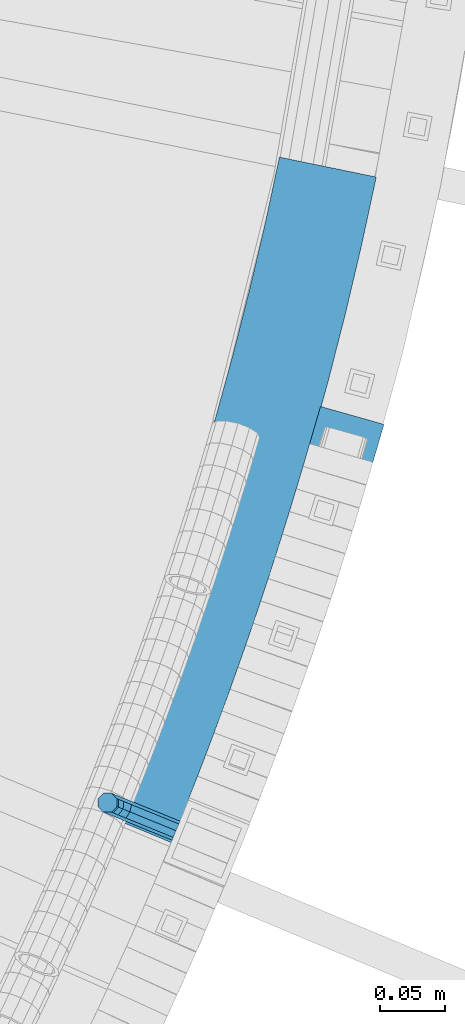
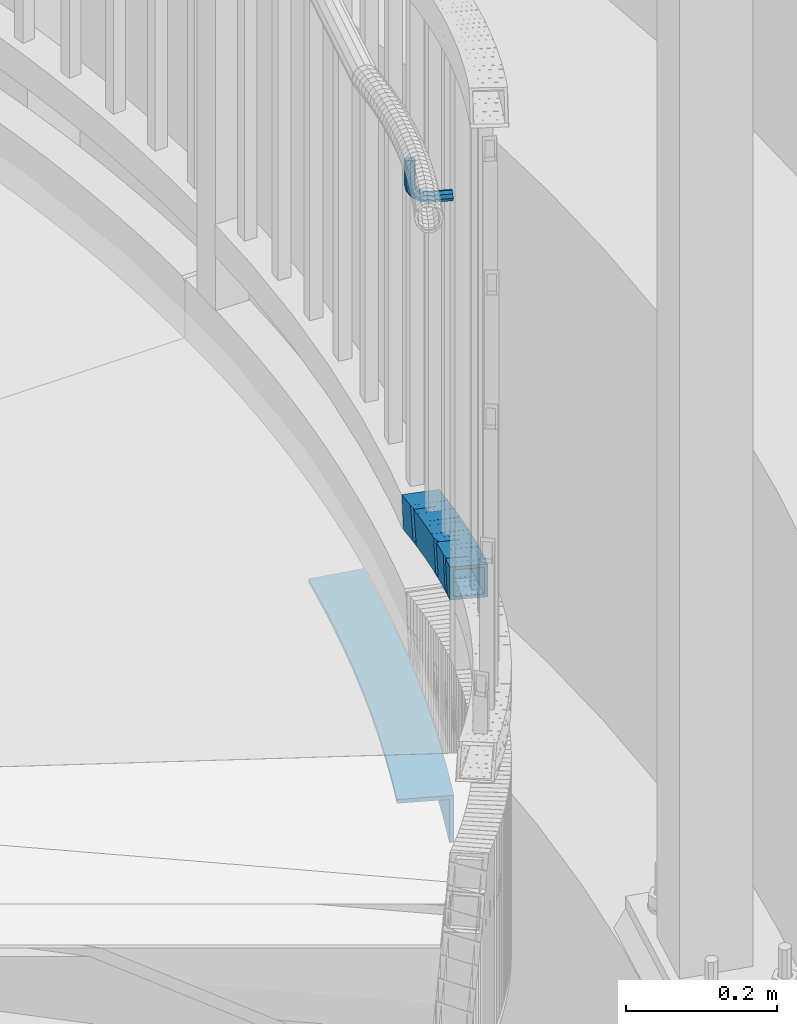
# One storey, part 495 of 975: 3 beams.
"""IFC2X3 building model written with IfcOpenShell, lengths in millimetres."""

from ifc_helpers import new_model, si_unit, frame, origin_with_axes, place, context, subcontext, project, spatial, faceted_brep, material, type_object, element, save


model = new_model("IFC2X3")

# Units and contexts
model_context = context("Model", 3, precision=1e-05, world=origin_with_axes())
body_context = subcontext(model_context, "Body", "Model", "MODEL_VIEW")
ifc_project = project(units=[si_unit("LENGTHUNIT", "METRE", prefix="MILLI"), si_unit("AREAUNIT", "SQUARE_METRE"), si_unit("VOLUMEUNIT", "CUBIC_METRE"), si_unit("MASSUNIT", "GRAM", prefix="KILO"), si_unit("TIMEUNIT", "SECOND"), si_unit("PLANEANGLEUNIT", "RADIAN"), si_unit("SOLIDANGLEUNIT", "STERADIAN"), si_unit("THERMODYNAMICTEMPERATUREUNIT", "DEGREE_CELSIUS"), si_unit("LUMINOUSINTENSITYUNIT", "LUMEN")], contexts=[model_context])

# Site, building, storey
site_placement = place(None, origin_with_axes())
site = spatial("IfcSite", under=ifc_project, at=site_placement, CompositionType="ELEMENT")
building_placement = place(site_placement, origin_with_axes())
building = spatial("IfcBuilding", under=site, at=building_placement, Name="Undefined", CompositionType="ELEMENT")
storey_placement = place(building_placement, origin_with_axes())
storey = spatial("IfcBuildingStorey", under=building, at=storey_placement, Name="Undefined", CompositionType="ELEMENT", Elevation=0.0)

# Beams
ifc_material_1 = material(Name="STEEL/A36")
beam_type_1 = type_object("IfcBeamType", PredefinedType="NOTDEFINED")
beam_1_placement = place(storey_placement, frame((37368.7829717512, 2329.61663625139, 3045.06408771674), z_axis=(0.0, 0.0, 1.0), x_axis=(-0.925815306032597, 0.377976215013284, 0.0)))
element("IfcBeam", 1, at=beam_1_placement, inside=storey, type_object=beam_type_1, material=ifc_material_1, Name="BRACKET", context=body_context, shape_type="Brep", body=[
    faceted_brep([(-4.22995071858168e-07, -7.93750000000728, 0.0), (-2.99107341561466e-07, -5.61266007567065, -5.61266007566792), (31.7499842270954, -5.6126618385606, -5.6126600757234), (31.7499840980236, -7.93750176289177, -5.54791768081486e-11), (-1.09139364212751e-11, 1.81898940354586e-12, -7.9375), (31.7499845387247, -1.7628881323617e-06, -7.93750000005548), (2.99089151667431e-07, 5.61266007567428, -5.61266007566792), (31.7499848503612, 5.61265831278433, -5.6126600757234), (4.22980519942939e-07, 7.93750000001091, 0.0), (31.7499849794513, 7.93749823711914, -5.54791768081486e-11), (2.99089151667431e-07, 5.61266007567428, 5.61266007566792), (31.7499848503794, 5.61265831278433, 5.61266007561244), (-1.09139364212751e-11, 1.81898940354586e-12, 7.9375), (31.7499845387538, -1.7628881323617e-06, 7.93749999994452), (-2.99107341561466e-07, -5.61266007567065, 5.61266007566792), (31.7499842271172, -5.6126618385606, 5.61266007561244), (44.5076933192395, -2.47124626184814e-06, -5.39983394420233), (43.618015285665, -5.61266249752225, -3.25196192174644), (41.4701431341346, -7.93750230259684, 1.9334598451087), (39.322271240766, -5.61266225900181, 7.11888161196475), (38.432593830461, -2.1339365048334e-06, 9.26675363442064), (39.3222718640282, 5.61265789233948, 7.11888161196475), (41.4701440155623, 7.93749769741771, 1.9334598451087), (43.6180159089272, 5.61265765382268, -3.25196192174644), (53.6792468227941, 5.61265709518557, 3.47073764605557), (55.32315658683, -3.07176742353477e-06, 1.82682757038583), (49.7104969518768, 7.93749723988003, 7.43948764606012), (45.7417468228014, 5.61265753590487, 11.4082376460638), (44.0978364355033, -2.44848706643097e-06, 13.0521477217335), (45.7417461995356, -5.61266261544006, 11.4082376460638), (49.7104960704528, -7.93750276013816, 7.43948764606012), (53.6792461995283, -5.612663056163, 3.47073764605648), (60.4019463906188, 5.61265672191075, 13.5319685599115), (62.5498181014409, -3.47302193404175e-06, 12.6422908379673), (55.2165247528465, 7.93749693416248, 15.6798405823693), (50.0311028569122, 5.61265729774459, 17.8277126048279), (47.8832305228243, -2.65866765403189e-06, 18.7173903267721), (50.03110223365, -5.61266285360034, 17.8277126048279), (55.2165238714188, -7.93750306585207, 15.6798405823693), (60.4019457673567, -5.61266342943782, 13.5319685599115), (62.7626445446149, 5.61265659083438, 25.3999996184748), (65.0874841573168, -3.61392449121922e-06, 25.3999996184748), (57.1499845980288, 7.93749682680573, 25.3999996184748), (51.5373243932772, 5.61265721410746, 25.3999996184748), (49.2124841573132, -2.73247496807016e-06, 25.3999996184748), (51.5373237700151, -5.61266293723384, 25.3999996184748), (57.1499837166011, -7.93750317320519, 25.3999996184748), (62.7626439213527, -5.61266356051055, 25.3999996184748), (65.0874827799671, -8.13710357761011e-07, 63.5532656203741), (62.7626427854739, -5.61266086031537, 61.7133802904182), (57.1499826807376, -7.93750071448449, 60.9512776088477), (51.5373226341253, -5.61266071998034, 61.7133869906074), (49.2124827799453, -6.15244061918929e-07, 63.5532750958728), (51.5373227744385, 5.61265943136095, 65.3931604258296), (57.1499828791711, 7.93749928552643, 66.1552631073992), (62.7626429257907, 5.61265929102228, 65.3931537256394)], [[[0, 1, 2, 3]], [[1, 4, 5, 2]], [[4, 6, 7, 5]], [[6, 8, 9, 7]], [[8, 10, 11, 9]], [[10, 12, 13, 11]], [[12, 14, 15, 13]], [[14, 0, 3, 15]], [[14, 12, 10, 8, 6, 4, 1, 0]], [[2, 5, 16, 17]], [[3, 2, 17, 18]], [[15, 3, 18, 19]], [[13, 15, 19, 20]], [[11, 13, 20, 21]], [[9, 11, 21, 22]], [[7, 9, 22, 23]], [[5, 7, 23, 16]], [[23, 24, 25, 16]], [[22, 26, 24, 23]], [[21, 27, 26, 22]], [[20, 28, 27, 21]], [[19, 29, 28, 20]], [[18, 30, 29, 19]], [[17, 31, 30, 18]], [[16, 25, 31, 17]], [[24, 32, 33, 25]], [[26, 34, 32, 24]], [[27, 35, 34, 26]], [[28, 36, 35, 27]], [[29, 37, 36, 28]], [[30, 38, 37, 29]], [[31, 39, 38, 30]], [[25, 33, 39, 31]], [[32, 40, 41, 33]], [[34, 42, 40, 32]], [[35, 43, 42, 34]], [[36, 44, 43, 35]], [[37, 45, 44, 36]], [[38, 46, 45, 37]], [[39, 47, 46, 38]], [[33, 41, 47, 39]], [[47, 41, 48, 49]], [[46, 47, 49, 50]], [[45, 46, 50, 51]], [[44, 45, 51, 52]], [[43, 44, 52, 53]], [[42, 43, 53, 54]], [[40, 42, 54, 55]], [[41, 40, 55, 48]], [[54, 53, 52, 51, 50, 49, 48, 55]]]),
])
ifc_material_2 = material()
beam_type_2 = type_object("IfcBeamType", Name="HSS2X2X.188_TUBES", PredefinedType="NOTDEFINED")
beam_2_placement = place(storey_placement, frame((37461.5164000018, 2508.53605289768, 2344.33794306487), z_axis=(-0.950871431631883, 0.309586047014935, 5.81717358727475e-11), x_axis=(0.294802179000737, 0.905463837001894, -0.305330829000651)))
element("IfcBeam", 2, at=beam_2_placement, inside=storey, type_object=beam_type_2, material=ifc_material_2, Name="HANDRAIL", ObjectType="HSS2X2X.188_TUBES", context=body_context, shape_type="Brep", body=[
    faceted_brep([(96.7366792999055, -25.8585898348501, -24.1435934114488), (96.8567889623937, 24.9389981357381, -24.6238329788175), (155.260260092999, 24.8173161677751, -22.8878853430069), (147.632993601499, -25.9646308554684, -22.6307837312488), (95.3485836847176, 25.4225931418969, 26.151470592049), (95.2284740222294, -25.3749948286913, 26.631710159425), (145.748198229005, -25.4802512345777, 28.1333263151173), (153.375464720504, 25.3016957886657, 27.8762247033665), (95.4787176486443, 20.6149822378266, 21.436308341712), (95.3811285478714, -20.6580579882757, 21.8265029902104), (96.6065453359843, -21.0509789307807, -19.4284311611191), (96.7041344367499, 20.2220612953224, -19.8186258096102), (154.36850429325, 20.1019192238045, -18.1046467500564), (152.837108053098, 20.4954776657778, 23.141192662617), (146.639954028753, -20.7648542906063, 23.3500877221668), (148.171350268904, -21.1584127325796, -17.8957516904993), (0.0, -25.400000000016, -25.4000000000196), (0.0, 25.3999999999724, -25.4000000000342), (18.9957890070255, 25.4000000000033, -25.3999999999287), (18.9957890070727, -25.4000000000106, -25.4000000000524), (0.0, 25.400000000016, 25.4000000000196), (0.0, -25.399999999976, 25.4000000000378), (18.9957890070546, -25.4000000000069, 25.3999999999796), (18.9957890070091, 25.4000000000078, 25.400000000096), (0.0, 20.6375000000116, 20.6375000000189), (0.0, -20.6374999999825, 20.6375000000335), (0.0, -20.6375000000153, -20.6375000000153), (0.0, 20.6374999999753, -20.6375000000298), (18.9957890070273, 20.6375000000025, -20.6374999999316), (18.9957890070145, 20.6375000000044, 20.6375000000917), (18.9957890070527, -20.6375000000062, 20.6374999999825), (18.9957890070673, -20.6375000000089, -20.6375000000335), (77.1467147449421, 25.0530573657934, -24.8958697393682), (76.2325595611073, 25.3461745613404, 25.3909398963879), (77.1245082366768, 24.9711102747369, -24.8957957655512), (57.0505389284226, -25.420255620671, 25.8422657576812), (57.9738550767488, -25.7163102127006, -24.9484798459671), (77.062296197606, -25.7460184417378, -24.6013012215917), (76.1389800492798, -25.4499638497091, 26.1894443820565), (57.1349574757587, 25.378820186861, 25.5476972399265), (76.2233985966177, 25.3491119578212, 25.8948758642728), (76.2248761730079, 25.3486381837229, 25.8135957883424), (76.2409359542999, -20.7260543437278, 20.9879711992326), (95.037833513974, 25.4232092055199, 26.2494496363652), (77.3170498575291, -25.8277033336444, -24.5954890550638), (77.1264093380832, 24.9705007004559, -24.9777495746675), (96.2159033238313, 25.0454697247387, -24.5354838026979), (96.4065438432772, -25.7527343093607, -24.1532232830796), (76.0987368961723, 25.3488308277956, 25.8106682735597), (58.0582736240831, 25.0827655948324, -25.2430483637218), (57.2136041258509, 20.5886517119015, 20.8136806381226), (57.145014056141, -20.6855973817183, 21.0530175588065), (57.8952084266566, -20.926141737742, -20.2144632441559), (57.9637984963647, 20.3481073558787, -20.4538001648398), (77.0318333414216, 20.3184308860764, -20.1069926877462), (76.0748887157533, 20.5592970171401, 21.1567277626164), (76.2313441815368, -20.7153023253159, 21.4001577886011), (76.9836495475156, -20.9558499667801, -19.8672846197951), (76.2335949006829, -20.7153504121379, 21.3925101158457), (77.0521163327339, 20.2442123710844, -20.1061913538651), (77.0321149689626, 20.2441345752723, -20.1065545017191), (76.0766561215969, 20.5504954767166, 21.0819332781903), (95.1661501073468, 20.6254645010004, 21.5241990501672), (95.3210455293975, -20.6480762767069, 21.8347857223562), (96.2782272499062, -20.9549896048411, -19.4279726968889), (77.18873326416, -21.0299586291248, -19.8702384688659), (76.233581902763, -20.7230373272814, 21.3925669897799), (77.1398518623064, 20.9233002661749, -24.87192252362), (77.0534646332853, 20.2436592277027, -20.1803704271661), (77.0473682223146, 16.6382677249621, -20.1536948636858), (96.1233318278537, 20.3185511728652, -19.7385593690706), (19.586033212543, -25.5892574927839, -25.3962183114199), (57.6407831223223, -25.609513103911, -24.9539525402652), (57.0797740346807, 25.3793846395083, 25.6533352330734), (19.0250241249014, 25.3996402506345, 25.2110694619114), (19.6152683263117, 25.2103827674473, -25.5851488363478), (19.0776187268693, 20.6194310871888, 20.4666362331627), (19.0538651969309, -20.6552766242494, 20.6201422846643), (19.5334386105769, -20.809048329339, -20.6517850826713), (19.5571921405153, 20.4656593821001, -20.8052911341729), (57.670018236091, 25.1901271563211, -25.1428830651857), (57.1086151067102, -20.6755322353765, 21.0624080558264), (57.1323686366468, 20.5991754760616, 20.9089020043248), (57.6119420502946, 20.4454037709729, -20.3630253630181), (57.5881885203562, -20.8293039404662, -20.2095193115165), (-0.0786638557456172, 20.6475389881271, 20.7362271898237), (-37.948109538167, 20.6083781665893, 20.9883187091109), (-38.2229557700066, 20.6965055955079, -20.2856721095741), (-0.353510087585164, 20.7356664170466, -20.5377636288613), (-0.338272282593607, -25.2915354817324, -25.3987579389068), (-0.390080096927704, 25.5083215646337, -25.2899460723711), (-0.0518078115874232, 25.399857036733, 25.5088118583226), (-0.0365700065995043, -20.627344862045, 20.6478175482698), (-0.311416238437232, -20.5392174331255, -20.6261732704224), (-37.9060156890191, -20.6665056835836, 20.8999090675497), (-38.1808619208587, -20.578378254665, -20.3740817511352), (-38.2077179650132, -25.330696303271, -25.1466664196269), (-37.8694456796748, -25.4391608311707, 25.6520915110668), (-37.9212534940125, 25.3606962151953, 25.7609033776025), (-38.259525779351, 25.4691607430959, -25.0378545530912), (-37.943759409578, 25.3598950076466, 25.9527627758289), (-56.8199193276287, 25.3302291871478, 26.2994459639885), (-56.7725825649541, -25.4688690501698, 25.9992701574374), (-57.7058817951656, -25.1696134773392, -24.79127422491), (-38.8027449019282, -25.1399052597571, -25.1384528773997), (-57.7801955330269, 25.6294423628979, -24.4906029540434), (-38.8770586397895, 25.6591505804781, -24.8377816065185), (-56.9462637977231, 25.3620482506194, 20.8923197386903), (-57.625351905257, -20.435257202269, -20.0014727574307), (-56.8670462807113, -20.6784023551954, 21.2658445532288), (-37.9639093874739, -20.6486941376133, 20.9186659007537), (-38.7222150120197, -20.4055489846887, -20.3486514099059), (-56.9274261927221, 20.5958305149961, 21.5101399608175), (-38.0242892994866, 20.6255387325764, 21.1629613083351), (-57.6857318172715, 20.8389756679226, -19.7571773498421), (-38.7825949240341, 20.8686838855037, -20.1043560023172), (-56.9260785297829, 20.6029855483157, 21.5841295916616), (-56.9300083051094, 20.6045886892689, 21.3702988910954), (-56.9232425980936, 18.6244839761293, 21.5692388421812), (-76.8919372546588, -25.1086059243789, -24.3431749339798), (-76.9373693852813, 25.6899398541536, -23.961490886446), (-58.0047522740515, 25.7101954522714, -24.4037566784391), (-57.9593201434291, -25.0883503262612, -24.7854407259729), (-94.5147354854525, 20.6310513116314, 22.5219002199374), (-95.5518787430665, 20.9636037124856, -18.7387271114276), (-76.8212670862304, 20.9178653238923, -19.2099157302509), (-75.8570207073572, 20.5854909303471, 22.0525454002418), (-94.6238209254952, -20.6424859953695, 22.1919857813118), (-75.8206549336992, -20.6884015548112, 21.7189719803937), (-76.8494265385525, -20.355869596744, -19.5418659488641), (-95.6609641831092, -20.3099335945153, -19.0686415500531), (-75.8123507604814, -20.6884003607756, 21.7160768465328), (-95.7932213405311, -25.0338933913781, -23.8675502158076), (-94.5167373311597, -25.4431886539678, 26.914760345855), (-94.3824783280324, 25.3550111084951, 27.3208088857064), (-95.658962337402, 25.7643063710848, -23.4615016759708), (-76.9816836959726, -25.0798293936059, -24.3407746146331), (-75.7051996866012, -25.4891246561983, 26.4415359470368), (-75.570940683474, 25.3090751062655, 26.8475844868808), (-75.6588445928173, 25.3095193284171, 26.8210758474961), (-76.8474246928436, 25.7183703688561, -23.9347260747891), (-75.5852489829049, 25.3136629578403, 26.278358002266), (-76.8475001488841, 25.6898208419307, -23.9349542815689), (-56.818014704686, 25.3296767253669, 26.3809542043455), (-75.9311365098765, -20.6556816945813, 16.9909494715321), (-76.9143961006303, 0.37908680601231, -24.1372722110609), (-76.8013446520472, -2.03941088464944, -19.4085056854019), (-76.7410614564778, 20.8919889944063, -19.2380944215984), (-76.7404094805424, 20.8917947019436, -19.2121583226326), (-75.812357800678, -20.6910784120755, 21.7160569449989), (-76.8212440386742, 20.8917071451742, -19.2101271392676), (-75.8576292007983, 20.5827310911591, 22.0263704716199), (-57.8892363646792, 20.9121581548861, -19.6784729126375), (-76.7849398697781, -20.3819158882879, -19.5463254092538), (-57.8523227585483, -20.3616602901711, -19.9885912012542), (-56.8880984834377, -20.6708317557805, 21.2739863910028), (-76.9366969028124, 25.6897242275663, -23.9327129757949), (-134.326123177927, -24.7553069966798, -22.47828815088), (-134.175492297347, 26.0399618437677, -21.80155055879), (-115.366060382677, 25.9947010424021, -22.590994988459), (-115.516691263258, -24.8005677980454, -23.2677325805562), (-132.26074872264, 20.6594288475644, 24.1279218334312), (-133.990076161046, 21.2139250580021, -17.1071067899611), (-115.180644246377, 21.1686642566365, -17.8965512196373), (-114.01697305167, 20.7955415886381, 9.85066076365911), (-113.610208303107, 20.6145503839762, 23.3451461860168), (-113.573704398439, -20.6569878866649, 22.7886281101892), (-132.383136313108, -20.611727085301, 23.5780725398508), (-113.552228866045, -13.4150768170148, 22.8851109829266), (-134.112463751519, -20.0572308748615, -17.6569560835414), (-115.303031836849, -20.1024916762271, -18.4464005132104), (-132.197720176806, -25.4377638710666, 28.2725163086798), (-132.047089296228, 25.3575049693818, 28.9492539007842), (-113.247698771871, 25.3154638664673, 27.9203770723034), (-113.237657381556, 25.3122441680171, 28.1598094711007), (-113.245633926945, 25.3148017890253, 27.9696123633184), (-113.285718152718, 25.3149045503651, 27.9708212992118), (-113.38828826214, -25.4830246724314, 27.4830718790035), (-114.080977009953, 25.5069829818367, 8.05557341469103), (-94.6091007741288, 25.3543290932066, 27.4083801361339), (-96.1391988746236, 25.84494386804, -23.3662010728949), (-115.0107498202, 25.8051078391882, -22.7978895393899), (-114.918386369431, -24.9924099003847, -23.2915093246993), (-96.0468354238546, -24.9525738715329, -23.8598208582043), (-113.615439343117, 20.5982209114109, 23.170297826422), (-113.540394039364, -20.6747622519933, 22.7692317508481), (-114.783598746018, -20.2761377474417, -18.4851154814824), (-114.858644049771, 20.9968454159634, -18.0840494059157), (-95.9870931041933, 21.0366814448153, -18.6523609394208), (-94.743888397541, 20.6380569402627, 22.6019862929097), (-94.6688430937902, -20.6349262231415, 22.2009202173431), (-95.9120478004425, -20.2363017185889, -19.0534270149874), (-193.897690309863, -24.5779010809383, -19.5134277229517), (-177.613331667151, 26.2087191422834, -19.513427718739), (-172.454751300107, 26.2070352593919, -19.8009409952647), (-172.521708491902, -24.5848787080149, -20.7048172398281), (-190.331395169918, -25.4843443022655, 31.1585500971923), (-169.695504571639, -25.4910803460261, 30.0084095357161), (-174.047036527207, 25.3022759209571, 31.1585501014051), (-169.628547379845, 25.3008336213816, 30.912285780294), (-189.139076716534, -20.6381196043385, 26.4080521769502), (-175.908035319329, 20.6260093270284, 26.4080521803771), (-169.8997812341, 20.6240480904999, 26.0731823721508), (-169.954183952432, -20.6443820080185, 25.3387829234343), (-192.03669151774, -19.9016344870106, -14.7629298019165), (-172.250474637645, -19.9080931771332, -15.8657138316994), (-178.805650120536, 21.3624944443563, -14.7629297984968), (-172.196071919314, 21.3603369213843, -15.131314382983), (-153.170607551901, -24.8038217257399, -21.6533899276037), (-153.353045104617, 25.9907251780551, -20.9317796567775), (-134.603626490938, 26.0697220300281, -21.7521826953016), (-134.42118893822, -24.7248248737687, -22.4737929661205), (-151.169521210502, -20.6802911215145, 24.4030722351526), (-132.423273909271, -20.6089370753762, 23.5827007744883), (-134.229842264009, -20.0296741333132, -17.6486755089863), (-152.97926087769, -20.1086709852862, -16.8282724704768), (-151.169536861478, -20.6879206316135, 24.4029657333012), (-151.172385232216, -20.6804059630431, 24.4108514781765), (-151.320923034529, 20.5826354319843, 24.989412158051), (-132.571504420854, 20.6616322839564, 24.1690091195414), (-151.317696987377, 20.5898329834017, 25.0638330092697), (-153.124520917601, 21.2346686585834, -16.1670701557814), (-153.124261047778, 21.1608625886529, -16.1682379222329), (-153.093396217824, 21.160994817461, -16.1697423331207), (-153.096986600542, 21.1620268997549, -16.2432988986184), (-153.108075934922, 15.7562174059167, -16.3187596703283), (-134.378072775595, 21.2408952260212, -17.0623671639405), (-153.328256046672, 19.9615635805312, -20.9458024743217), (-132.380157746642, 25.3567830244119, 28.9941265766756), (-151.200428177379, -20.6790406924265, 23.7700919475974), (-153.349480589934, 25.9895822424678, -20.8504266064847), (-153.315422845813, 25.9897281501217, -20.8520866461258), (-150.974732992949, 25.2784385733912, 29.8077542600877), (-150.865433897579, 25.2854605513812, 29.3411063412568), (-150.947138813941, -25.5167607270687, 29.0929193593547), (-153.315249879101, 26.0709761426579, -20.8508235381305), (-153.423383350266, -24.7227710128336, -21.6404798301955), (-172.171749099494, -24.6970906216357, -20.7249896608555), (-172.063615628327, 26.0966565338549, -19.9353333687977), (-169.587371092002, 25.3026668196217, 30.7980658207598), (-150.839005342774, 25.2769864284219, 29.8825756514198), (-169.829656530204, 20.6151895595021, 25.9677793693554), (-169.917514975528, -20.654730004333, 25.3261836320526), (-171.92946366129, -20.009613361517, -15.8947032094584), (-171.841605215968, 21.2603062023181, -15.2531074721555), (-153.181097912064, -20.0352937527168, -16.8101933787912)], [[[0, 1, 2, 3]], [[4, 5, 6, 7]], [[1, 4, 7, 2]], [[0, 5, 4, 1], [8, 9, 10, 11]], [[8, 11, 12, 13]], [[9, 8, 13, 14]], [[10, 9, 14, 15]], [[11, 10, 15, 12]], [[6, 3, 2, 7], [14, 13, 12, 15]], [[5, 0, 3, 6]], [[16, 17, 18, 19]], [[20, 21, 22, 23]], [[17, 20, 23, 18]], [[16, 21, 20, 17], [24, 25, 26, 27]], [[24, 27, 28, 29]], [[25, 24, 29, 30]], [[26, 25, 30, 31]], [[27, 26, 31, 28]], [[22, 19, 18, 23], [30, 29, 28, 31]], [[21, 16, 19, 22]], [[32, 33, 34]], [[35, 36, 37, 38]], [[39, 35, 38, 40]], [[40, 38, 41]], [[38, 42, 5, 43, 41]], [[44, 45, 46, 47]], [[33, 48, 41, 43, 46, 45, 34]], [[32, 49, 39, 40, 41, 48, 33]], [[36, 35, 39, 49], [50, 51, 52, 53]], [[50, 53, 54, 55]], [[51, 50, 55, 56]], [[57, 52, 51, 56, 58]], [[54, 53, 52, 57, 59, 60]], [[59, 61, 56, 55, 54, 60]], [[56, 61, 62, 63, 58]], [[58, 63, 64, 65, 66]], [[34, 45, 44, 42, 66, 65, 67]], [[37, 36, 49, 32, 34, 67]], [[68, 59, 57, 58, 66, 42, 38, 37, 67, 69]], [[69, 70, 62, 61, 59, 68]], [[67, 65, 64, 70, 69]], [[5, 47, 46, 43], [63, 62, 70, 64]], [[42, 44, 47, 5]], [[71, 72, 35, 22]], [[22, 35, 73, 74]], [[71, 22, 74, 75], [76, 77, 78, 79]], [[71, 75, 80, 72]], [[74, 73, 80, 75]], [[35, 72, 80, 73], [81, 82, 83, 84]], [[76, 79, 83, 82]], [[78, 84, 83, 79]], [[77, 81, 84, 78]], [[76, 82, 81, 77]], [[85, 86, 87, 88]], [[21, 89, 90, 91], [92, 85, 88, 93]], [[85, 92, 94, 86]], [[93, 95, 94, 92]], [[88, 87, 95, 93]], [[96, 97, 98, 99], [86, 94, 95, 87]], [[89, 21, 97, 96]], [[91, 98, 97, 21]], [[90, 99, 98, 91]], [[89, 96, 99, 90]], [[97, 100, 101, 102]], [[102, 103, 104, 97]], [[103, 105, 106, 104]], [[100, 106, 105, 107, 101]], [[108, 109, 110, 111]], [[109, 112, 113, 110]], [[112, 114, 115, 113]], [[97, 104, 106, 100], [110, 113, 115, 111]], [[114, 108, 111, 115]], [[116, 117, 107, 105, 103, 102, 118], [112, 109, 108, 114]], [[119, 120, 121, 122]], [[123, 124, 125, 126]], [[127, 123, 126, 128]], [[129, 130, 127, 128, 131]], [[132, 133, 134, 135], [123, 127, 130, 124]], [[133, 132, 136, 137]], [[134, 133, 137, 138]], [[138, 137, 139]], [[140, 135, 134, 138, 139, 141]], [[140, 141, 142]], [[139, 143, 121, 120, 142, 141]], [[137, 144, 102, 143, 139]], [[136, 145, 146, 147, 148, 129, 131, 149, 144, 137]], [[125, 124, 130, 129, 148, 150]], [[126, 125, 150, 148, 151, 128]], [[147, 146, 152, 117, 116, 151, 148]], [[145, 153, 154, 152, 146]], [[131, 155, 154, 153, 149]], [[128, 151, 116, 118, 155, 131]], [[102, 122, 121, 143, 102, 101, 107, 117, 152, 154, 155, 118]], [[144, 119, 122, 102]], [[149, 153, 145, 156, 142, 120, 119, 144]], [[145, 136, 132, 135, 140, 142, 156]], [[157, 158, 159, 160]], [[161, 162, 163, 164, 165]], [[166, 167, 161, 165, 168]], [[169, 167, 166, 170]], [[162, 169, 170, 163]], [[157, 171, 172, 158], [161, 167, 169, 162]], [[173, 159, 158, 172, 174, 175, 176]], [[164, 163, 170, 166, 168, 177, 160, 159, 173, 178]], [[171, 157, 160, 177]], [[172, 171, 177, 174]], [[174, 177, 175]], [[175, 177, 133, 179, 176]], [[173, 176, 179, 180, 181, 178]], [[182, 181, 180, 183]], [[168, 165, 164, 178, 181, 182, 177], [184, 185, 186, 187]], [[184, 187, 188, 189]], [[185, 184, 189, 190]], [[186, 185, 190, 191]], [[187, 186, 191, 188]], [[133, 183, 180, 179], [190, 189, 188, 191]], [[177, 182, 183, 133]], [[192, 193, 194, 195]], [[196, 192, 195, 197]], [[198, 196, 197, 199]], [[193, 198, 199, 194]], [[200, 201, 202, 203]], [[204, 200, 203, 205]], [[192, 196, 198, 193], [201, 200, 204, 206]], [[201, 206, 207, 202]], [[197, 195, 194, 199], [203, 202, 207, 205]], [[206, 204, 205, 207]], [[208, 209, 210, 211]], [[212, 213, 214, 215, 216]], [[217, 218, 219, 213, 212]], [[220, 221, 222, 223, 218, 217]], [[224, 225, 226, 219, 218, 223]], [[227, 215, 214, 226, 225]], [[171, 211, 210, 228], [213, 219, 226, 214]], [[229, 208, 211, 171]], [[216, 215, 227, 230, 231, 209, 208, 229]], [[232, 228, 210, 209, 231, 233]], [[234, 229, 171, 228, 232]], [[235, 233, 231]], [[227, 236, 237, 238, 235, 231, 230]], [[235, 238, 239, 240, 232, 233]], [[237, 197, 239, 238], [241, 242, 243, 244]], [[221, 244, 243, 245, 223, 222]], [[241, 244, 221, 220]], [[242, 241, 220, 217]], [[245, 243, 242, 217, 212]], [[236, 227, 225, 224, 223, 245, 212, 216, 229, 234]], [[197, 237, 236, 234]], [[239, 197, 234, 240]], [[240, 234, 232]]]),
])
beam_type_3 = type_object("IfcBeamType", Name="L3X3X1/4", PredefinedType="NOTDEFINED")
beam_3_placement = place(storey_placement, frame((37485.7867212924, 2841.07518473506, 2044.7), z_axis=(-0.956015990495209, 0.293314551151941, 0.0), x_axis=(-0.293314551151941, -0.956015990495209, 0.0)))
element("IfcBeam", 3, at=beam_3_placement, inside=storey, type_object=beam_type_3, material=ifc_material_1, Name="ANGLE", ObjectType="L3X3X1/4", context=body_context, shape_type="Brep", body=[
    faceted_brep([(3.61159372289876, 38.0999999999999, 37.9284377581789), (3.61159372289876, 31.75, 37.9284377581789), (55.7307038023591, 31.75, 33.4644335750272), (55.7307038023591, 38.0999999999999, 33.4644335750272), (-3.00966143574806, 31.75, -31.6070314651588), (-3.00966143574806, -38.0999999999999, -31.6070314651588), (50.4308330822914, -38.0999999999999, -36.1842122864546), (50.4308330822914, 31.75, -36.1842122864546), (-3.61159372289876, -38.0999999999999, -37.9284377581935), (-3.61159372289876, 38.0999999999999, -37.9284377581935), (49.9490266531975, 38.0999999999999, -42.5159073647665), (49.9490266531975, -38.0999999999999, -42.5159073647665), (107.925172505771, 31.75, 29.990760362125), (107.925172505771, 38.0999999999999, 29.990760362125), (103.948596803979, -38.0999999999999, -39.7459541122153), (103.948596803979, 31.75, -39.7459541122153), (103.587089921995, 38.0999999999999, -46.085655428069), (103.587089921995, -38.0999999999999, -46.085655428069), (160.176183960657, 31.75, 27.5086703631314), (160.176183960657, 38.0999999999999, 27.5086703631314), (157.524336814882, -38.0999999999999, -42.2909729504463), (157.524336814882, 31.75, -42.2909729504463), (157.28325980163, 38.0999999999999, -48.6363950698651), (157.28325980163, -38.0999999999999, -48.6363950698651), (212.464901911111, 31.75, 26.019058360398), (212.464901911111, 38.0999999999999, 26.019058360398), (211.138739300395, -38.0999999999999, -43.8183513332478), (211.138739300395, 31.75, -43.8183513332478), (211.018179063058, 38.0999999999999, -50.1672067599429), (211.018179063058, -38.0999999999999, -50.1672067599429), (264.77247650822, 31.75, 25.5224613523824), (264.77247650822, 38.0999999999999, 25.5224613523824), (264.772476508249, -38.0999999999999, -44.3275386475434), (264.772476508249, 31.75, -44.3275386475434), (264.772476508251, 38.0999999999999, -50.677538647542), (264.772476508251, -38.0999999999999, -50.677538647542), (317.080051105333, 31.75, 26.0190583600779), (317.080051105333, 38.0999999999999, 26.0190583600779), (318.406213716104, -38.0999999999999, -43.8183513335753), (318.406213716104, 31.75, -43.8183513335753), (318.526773953445, 38.0999999999999, -50.1672067602849), (318.526773953445, -38.0999999999999, -50.1672067602849), (369.368769055787, 31.75, 27.5086703624984), (369.368769055787, 38.0999999999999, 27.5086703624984), (372.020616201613, -38.0999999999999, -42.2909729511011), (372.020616201613, 31.75, -42.2909729511011), (372.261693214869, 38.0999999999999, -48.6363950705272), (372.261693214869, -38.0999999999999, -48.6363950705272), (421.619780510669, 31.75, 29.9907603611573), (421.619780510669, 38.0999999999999, 29.9907603611573), (425.596356212516, -38.0999999999999, -39.7459541132048), (425.596356212516, 31.75, -39.7459541132048), (425.957863094502, 38.0999999999999, -46.0856554290513), (425.957863094502, -38.0999999999999, -46.0856554290513), (473.814249214081, 31.75, 33.4644335737394), (473.814249214081, 38.0999999999999, 33.4644335737394), (479.114119934198, -38.0999999999999, -36.1842122877642), (479.114119934198, 31.75, -36.1842122877642), (479.595926363299, 38.0999999999999, -42.5159073660834), (479.595926363299, -38.0999999999999, -42.5159073660834), (525.933359293538, 38.0999999999999, 37.9284377565855), (533.15654673939, 38.0999999999999, -37.9284377598306), (525.933359293538, 31.75, 37.9284377565855), (532.554614452236, 31.75, -31.6070314668032), (532.554614452236, -38.0999999999999, -31.6070314668032), (533.15654673939, -38.0999999999999, -37.9284377598306)], [[[0, 1, 2, 3]], [[4, 5, 6, 7]], [[8, 9, 10, 11]], [[8, 5, 4, 1, 0, 9]], [[3, 2, 12, 13]], [[7, 6, 14, 15]], [[11, 10, 16, 17]], [[13, 12, 18, 19]], [[15, 14, 20, 21]], [[17, 16, 22, 23]], [[19, 18, 24, 25]], [[21, 20, 26, 27]], [[23, 22, 28, 29]], [[25, 24, 30, 31]], [[27, 26, 32, 33]], [[29, 28, 34, 35]], [[31, 30, 36, 37]], [[33, 32, 38, 39]], [[35, 34, 40, 41]], [[37, 36, 42, 43]], [[39, 38, 44, 45]], [[41, 40, 46, 47]], [[43, 42, 48, 49]], [[45, 44, 50, 51]], [[47, 46, 52, 53]], [[49, 48, 54, 55]], [[51, 50, 56, 57]], [[53, 52, 58, 59]], [[58, 52, 46, 40, 34, 28, 22, 16, 10, 9, 0, 3, 13, 19, 25, 31, 37, 43, 49, 55, 60, 61]], [[55, 54, 62, 60]], [[54, 48, 42, 36, 30, 24, 18, 12, 2, 1, 4, 7, 15, 21, 27, 33, 39, 45, 51, 57, 63, 62]], [[57, 56, 64, 63]], [[56, 50, 44, 38, 32, 26, 20, 14, 6, 5, 8, 11, 17, 23, 29, 35, 41, 47, 53, 59, 65, 64]], [[59, 58, 61, 65]], [[62, 63, 64, 65, 61, 60]]]),
])

save(model, "model.ifc")
